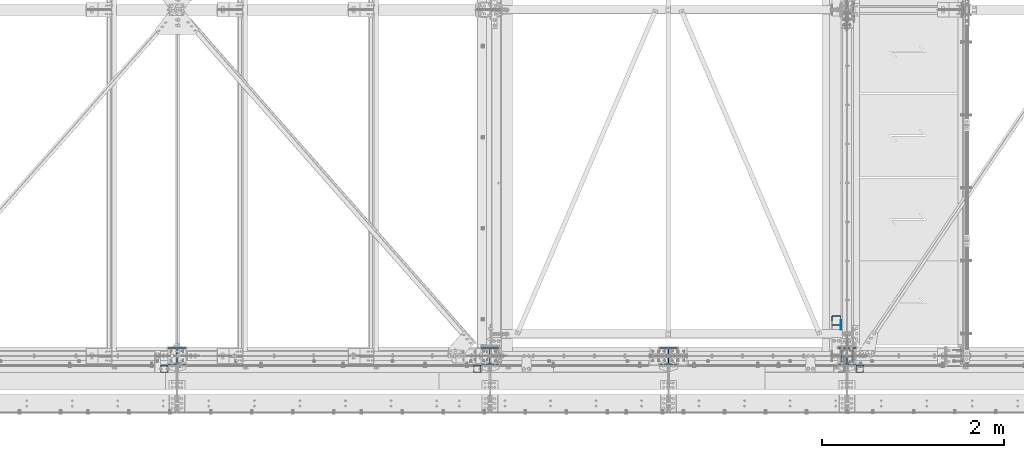
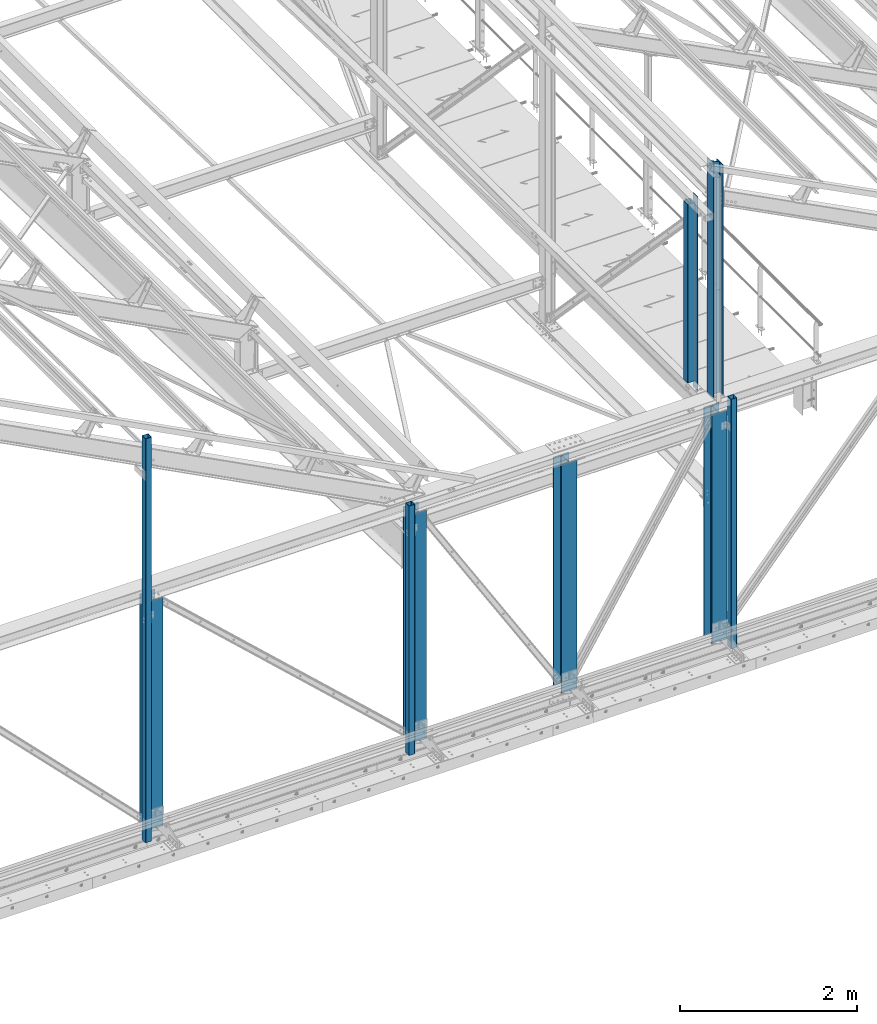
# One storey, part 8 of 496: 10 columns, 9 elements without a shape of their own.
"""IFC2X3 building model written with IfcOpenShell, lengths in millimetres."""

from ifc_helpers import new_model, si_unit, frame, origin_with_axes, origin_2d_with_axis, place, context, subcontext, project, spatial, rectangle, hollow_rectangle, i_section, extrude, clip, halfspace, material, type_object, element, aggregate, save


model = new_model("IFC2X3")

# Units and contexts
model_context = context("Model", 3, precision=1e-05, world=origin_with_axes())
body_context = subcontext(model_context, "Body", "Model", "MODEL_VIEW")
ifc_project = project(units=[si_unit("LENGTHUNIT", "METRE", prefix="MILLI"), si_unit("AREAUNIT", "SQUARE_METRE"), si_unit("VOLUMEUNIT", "CUBIC_METRE"), si_unit("MASSUNIT", "GRAM", prefix="KILO"), si_unit("TIMEUNIT", "SECOND"), si_unit("PLANEANGLEUNIT", "RADIAN"), si_unit("SOLIDANGLEUNIT", "STERADIAN"), si_unit("THERMODYNAMICTEMPERATUREUNIT", "DEGREE_CELSIUS"), si_unit("LUMINOUSINTENSITYUNIT", "LUMEN")], contexts=[model_context])

# Site, building, storey
site_placement = place(None, origin_with_axes())
site = spatial("IfcSite", under=ifc_project, at=site_placement, CompositionType="ELEMENT")
building_placement = place(site_placement, origin_with_axes())
building = spatial("IfcBuilding", under=site, at=building_placement, Name="Undefined", CompositionType="ELEMENT")
storey_placement = place(building_placement, origin_with_axes())
storey = spatial("IfcBuildingStorey", under=building, at=storey_placement, Name="Undefined", CompositionType="ELEMENT", Elevation=0.0)

# Assembly, column
assembly_1_placement = place(storey_placement, origin_with_axes())
assembly_1 = element("IfcElementAssembly", 1, at=assembly_1_placement, inside=storey, Name="MONTANT", AssemblyPlace="NOTDEFINED", PredefinedType="NOTDEFINED")
ifc_material_1 = material(Name="Undefined/S235-E24")
column_type_1 = type_object("IfcColumnType", PredefinedType="NOTDEFINED")
column_1_placement = place(assembly_1_placement, frame((23353.5001162734, 390.000078397763, 8555.00000000001), z_axis=(0.0, 0.0, 1.0), x_axis=(0.0, -1.0, 0.0)))
column_1 = element("IfcColumn", 2, at=column_1_placement, type_object=column_type_1, material=ifc_material_1, Name="MONTANT", context=body_context, shape_type="SweptSolid", body=[
    extrude(hollow_rectangle(XDim=100.0, YDim=100.0, WallThickness=4.0, InnerFilletRadius=4.0, OuterFilletRadius=8.0, at=origin_2d_with_axis()), frame((0.0, 0.0, 2460.0), z_axis=(0.0, 0.0, -1.0), x_axis=(0.0, 1.0, 0.0)), (0.0, 0.0, 1.0), 2460.0),
])

assembly_2_placement = place(storey_placement, origin_with_axes())
assembly_2 = element("IfcElementAssembly", 3, at=assembly_2_placement, inside=storey, Name="MONTANT", AssemblyPlace="NOTDEFINED", PredefinedType="NOTDEFINED")
column_type_2 = type_object("IfcColumnType", PredefinedType="NOTDEFINED")
column_2_placement = place(assembly_2_placement, frame((23609.9999999968, -139.999999996524, 5109.99999998342), z_axis=(0.0, 0.0, 1.0), x_axis=(0.0, 1.0, 0.0)))
column_2 = element("IfcColumn", 4, at=column_2_placement, type_object=column_type_2, material=ifc_material_1, Name="MONTANT", context=body_context, shape_type="SweptSolid", body=[
    extrude(hollow_rectangle(XDim=80.0, YDim=80.0, WallThickness=4.0, InnerFilletRadius=4.0, OuterFilletRadius=8.0, at=origin_2d_with_axis()), frame((0.0, 0.0, 3440.0), z_axis=(0.0, 0.0, -1.0), x_axis=(0.0, 1.0, 0.0)), (0.0, 0.0, 1.0), 3440.0),
])
aggregate(assembly_2, [column_2])

assembly_3_placement = place(storey_placement, origin_with_axes())
assembly_3 = element("IfcElementAssembly", 5, at=assembly_3_placement, inside=storey, Name="MONTANT", AssemblyPlace="NOTDEFINED", PredefinedType="NOTDEFINED")
column_3_placement = place(assembly_3_placement, frame((15974.9998811567, -140.000000002474, 5109.99999997945), z_axis=(0.0, 0.0, 1.0), x_axis=(0.0, 1.0, 0.0)))
column_3 = element("IfcColumn", 6, at=column_3_placement, type_object=column_type_2, material=ifc_material_1, Name="MONTANT", context=body_context, shape_type="SweptSolid", body=[
    extrude(hollow_rectangle(XDim=80.0, YDim=80.0, WallThickness=4.0, InnerFilletRadius=4.0, OuterFilletRadius=8.0, at=origin_2d_with_axis()), frame((0.0, 0.0, 5570.00143646038), z_axis=(0.0, 0.0, -1.0), x_axis=(0.0, 1.0, 0.0)), (0.0, 0.0, 1.0), 5570.0),
])
aggregate(assembly_3, [column_3])

assembly_4_placement = place(storey_placement, origin_with_axes())
assembly_4 = element("IfcElementAssembly", 7, at=assembly_4_placement, inside=storey, Name="MONTANT", AssemblyPlace="NOTDEFINED", PredefinedType="NOTDEFINED")
column_4_placement = place(assembly_4_placement, frame((19409.9999999968, -139.999999998195, 5109.99999999124), z_axis=(0.0, 0.0, 1.0), x_axis=(0.0, 1.0, 0.0)))
column_4 = element("IfcColumn", 8, at=column_4_placement, type_object=column_type_2, material=ifc_material_1, Name="MONTANT", context=body_context, shape_type="SweptSolid", body=[
    extrude(hollow_rectangle(XDim=80.0, YDim=80.0, WallThickness=4.0, InnerFilletRadius=4.0, OuterFilletRadius=8.0, at=origin_2d_with_axis()), frame((0.0, 0.0, 3440.0), z_axis=(0.0, 0.0, -1.0), x_axis=(0.0, 1.0, 0.0)), (0.0, 0.0, 1.0), 3440.0),
])
aggregate(assembly_4, [column_4])

assembly_5_placement = place(storey_placement, origin_with_axes())
assembly_5 = element("IfcElementAssembly", 9, at=assembly_5_placement, inside=storey, Name="MONTANT", AssemblyPlace="NOTDEFINED", PredefinedType="NOTDEFINED")
ifc_material_2 = material(Name="Undefined/S275-E28")
column_type_3 = type_object("IfcColumnType", Name="HEA140", PredefinedType="NOTDEFINED")
column_5_placement = place(assembly_5_placement, frame((23470.0, 0.0, 8560.0), z_axis=(0.0, 0.0, 1.0), x_axis=(-1.0, 0.0, 0.0)))
column_5 = element("IfcColumn", 10, at=column_5_placement, type_object=column_type_3, material=ifc_material_2, Name="MONTANT", ObjectType="HEA140", context=body_context, shape_type="Clipping", body=[
    clip(extrude(i_section(OverallWidth=140.0, OverallDepth=133.0, WebThickness=5.5, FlangeThickness=8.5, FilletRadius=12.0, at=origin_2d_with_axis()), frame((0.0, 0.0, 3251.41), z_axis=(0.0, 0.0, -1.0), x_axis=(0.0, 1.0, 0.0)), (0.0, 0.0, 1.0), 3251.41), halfspace(frame((-66.5, 69.9999999999991, 3171.22657322575), z_axis=(-0.460093242228747, -7.1029704621934e-09, 0.887870603441425), x_axis=(0.887870603441425, 0.0, 0.460093242228747)), False)),
])
aggregate(assembly_5, [column_5])

assembly_6_placement = place(storey_placement, origin_with_axes())
assembly_6 = element("IfcElementAssembly", 11, at=assembly_6_placement, inside=storey, Name="MONTANT", AssemblyPlace="NOTDEFINED", PredefinedType="NOTDEFINED")
column_type_4 = type_object("IfcColumnType", Name="HEA200", PredefinedType="NOTDEFINED")
column_6_placement = place(assembly_6_placement, frame((21510.0, 0.0, 5200.0), z_axis=(0.0, 0.0, 1.0), x_axis=(0.0, 1.0, 0.0)))
column_6 = element("IfcColumn", 12, at=column_6_placement, type_object=column_type_4, material=ifc_material_2, Name="MONTANT", ObjectType="HEA200", context=body_context, shape_type="SweptSolid", body=[
    extrude(i_section(OverallWidth=200.0, OverallDepth=190.0, WebThickness=6.5, FlangeThickness=10.0, FilletRadius=18.0, at=origin_2d_with_axis()), frame((0.0, 0.0, 3149.99931169993), z_axis=(0.0, 0.0, -1.0), x_axis=(0.0, 1.0, 0.0)), (0.0, 0.0, 1.0), 3150.0),
])
aggregate(assembly_6, [column_6])

assembly_7_placement = place(storey_placement, origin_with_axes())
assembly_7 = element("IfcElementAssembly", 13, at=assembly_7_placement, inside=storey, Name="MONTANT", AssemblyPlace="NOTDEFINED", PredefinedType="NOTDEFINED")
column_7_placement = place(assembly_7_placement, frame((23470.0, 0.0, 5200.0), z_axis=(0.0, 0.0, 1.0), x_axis=(0.0, 1.0, 0.0)))
column_7 = element("IfcColumn", 14, at=column_7_placement, type_object=column_type_4, material=ifc_material_2, Name="MONTANT", ObjectType="HEA200", context=body_context, shape_type="SweptSolid", body=[
    extrude(i_section(OverallWidth=200.0, OverallDepth=190.0, WebThickness=6.5, FlangeThickness=10.0, FilletRadius=18.0, at=origin_2d_with_axis()), frame((0.0, 0.0, 3149.99444626714), z_axis=(0.0, 0.0, -1.0), x_axis=(0.0, 1.0, 0.0)), (0.0, 0.0, 1.0), 3149.99),
])
aggregate(assembly_7, [column_7])

assembly_8_placement = place(storey_placement, origin_with_axes())
assembly_8 = element("IfcElementAssembly", 15, at=assembly_8_placement, inside=storey, Name="MONTANT", AssemblyPlace="NOTDEFINED", PredefinedType="NOTDEFINED")
column_8_placement = place(assembly_8_placement, frame((19550.0, 0.0, 5200.0), z_axis=(0.0, 0.0, 1.0), x_axis=(0.0, 1.0, 0.0)))
column_8 = element("IfcColumn", 16, at=column_8_placement, type_object=column_type_4, material=ifc_material_2, Name="MONTANT", ObjectType="HEA200", context=body_context, shape_type="SweptSolid", body=[
    extrude(i_section(OverallWidth=200.0, OverallDepth=190.0, WebThickness=6.5, FlangeThickness=10.0, FilletRadius=18.0, at=origin_2d_with_axis()), frame((0.0, 0.0, 3149.99444626714), z_axis=(0.0, 0.0, -1.0), x_axis=(0.0, 1.0, 0.0)), (0.0, 0.0, 1.0), 3149.99),
])
aggregate(assembly_8, [column_8])

assembly_9_placement = place(storey_placement, origin_with_axes())
assembly_9 = element("IfcElementAssembly", 17, at=assembly_9_placement, inside=storey, Name="MONTANT", AssemblyPlace="NOTDEFINED", PredefinedType="NOTDEFINED")
column_9_placement = place(assembly_9_placement, frame((16114.9984460551, 0.0, 5200.00068830009), z_axis=(0.0, 0.0, 1.0), x_axis=(0.0, 1.0, 0.0)))
column_9 = element("IfcColumn", 18, at=column_9_placement, type_object=column_type_4, material=ifc_material_2, Name="MONTANT", ObjectType="HEA200", context=body_context, shape_type="SweptSolid", body=[
    extrude(i_section(OverallWidth=200.0, OverallDepth=190.0, WebThickness=6.5, FlangeThickness=10.0, FilletRadius=18.0, at=origin_2d_with_axis()), frame((0.0, 0.0, 3149.99375796897), z_axis=(0.0, 0.0, -1.0), x_axis=(0.0, 1.0, 0.0)), (0.0, 0.0, 1.0), 3149.99),
])
aggregate(assembly_9, [column_9])

# Column
column_type_5 = type_object("IfcColumnType", PredefinedType="NOTDEFINED")
column_10_placement = place(assembly_1_placement, frame((23406.0001056693, 340.000078397788, 8450.0), z_axis=(0.0, 0.0, 1.0), x_axis=(0.0, -1.0, 0.0)))
column_10 = element("IfcColumn", 19, at=column_10_placement, type_object=column_type_5, material=ifc_material_1, context=body_context, shape_type="SweptSolid", body=[
    extrude(rectangle(XDim=5.0, YDim=100.0, at=origin_2d_with_axis()), frame((0.0, 0.0, 2670.0), z_axis=(0.0, 0.0, -1.0), x_axis=(0.0, 1.0, 0.0)), (0.0, 0.0, 1.0), 2670.0),
])

aggregate(assembly_1, [column_10, column_1])

save(model, "model.ifc")
